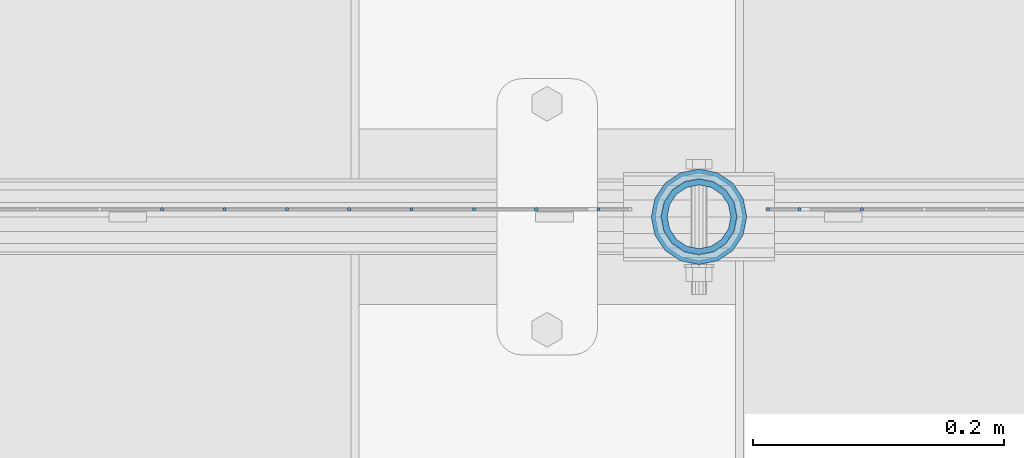
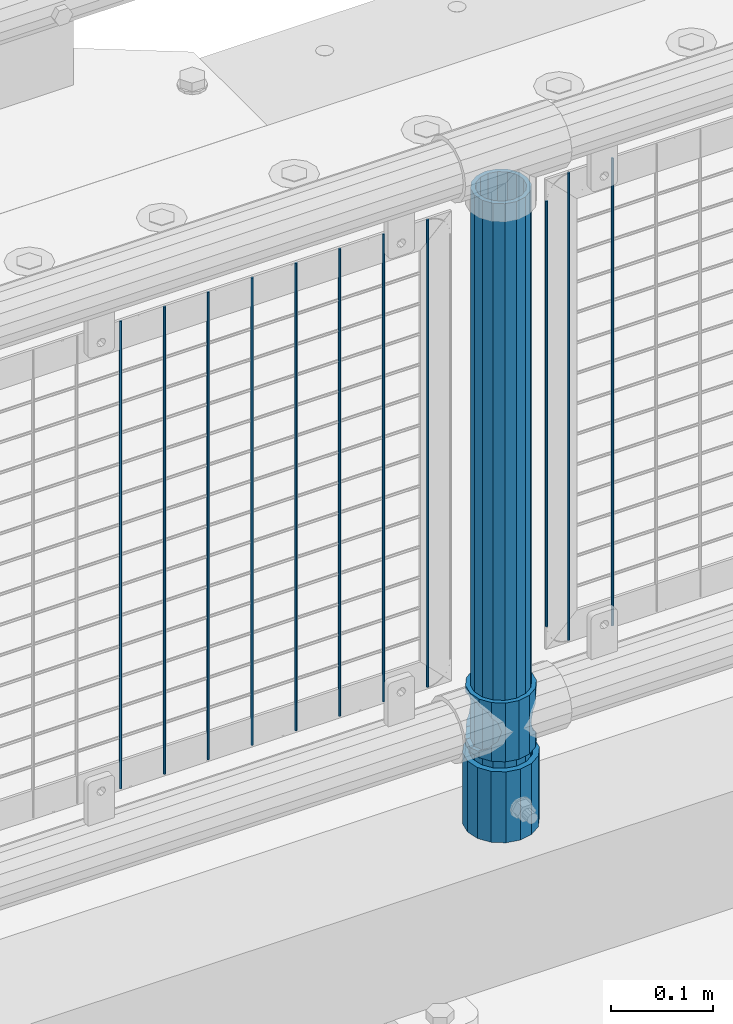
# One storey, part 70 of 257: 14 columns.
"""IFC2X3 building model written with IfcOpenShell, lengths in millimetres."""

import ifcopenshell
import ifcopenshell.guid

model = None  # the IFC model being written
_history = None  # IfcOwnerHistory: only IFC2X3 demands one
_inside = {}  # id of a spatial element -> (the spatial element, [elements in it])
_under = {}  # id of a project, library or spatial element -> (it, [spatial elements below it])
_declared = {}  # id of a project -> (the project, [libraries it declares])
_typed = {}  # id of a type object -> (the type object, [elements of that type])
_made_of = {}  # id of a material, layer set ... -> (it, [elements and type objects made of it])


def new_model(schema):
    """Start an empty IFC model of exactly this schema.

    Asked for "IFC4X3", IfcOpenShell would pick the latest addendum, in which some entities
    have other attributes; the version numbers below select the first issue.
    IFC2X3 requires an IfcOwnerHistory on every rooted entity: one is made here for all.
    """
    global model, _history
    if schema == "IFC4X3":
        model = ifcopenshell.file(schema_version=(4, 3, 0, 0))
    else:
        model = ifcopenshell.file(schema=schema)
    _inside.clear()
    _under.clear()
    _declared.clear()
    _typed.clear()
    _made_of.clear()
    _history = None
    if model.schema == "IFC2X3":
        org = make("IfcOrganization", Name="unknown")
        user = make(
            "IfcPersonAndOrganization",
            ThePerson=make("IfcPerson", FamilyName="unknown"),
            TheOrganization=org,
        )
        app = make(
            "IfcApplication",
            ApplicationDeveloper=org,
            Version="unknown",
            ApplicationFullName="unknown",
            ApplicationIdentifier="unknown",
        )
        _history = make(
            "IfcOwnerHistory",
            OwningUser=user,
            OwningApplication=app,
            ChangeAction="ADDED",
            CreationDate=0,
        )
    return model


def make(cls, **values):
    """One entity of the class cls with the attributes given. An attribute that is None is left unset."""
    return model.create_entity(
        cls, **{name: value for name, value in values.items() if value is not None}
    )


def rooted(cls, **values):
    """An entity with a GlobalId (a new one), such as an element, a storey or a relation."""
    return make(cls, GlobalId=ifcopenshell.guid.new(), OwnerHistory=_history, **values)


def si_unit(unit_type, name, prefix=None):
    """IfcSIUnit, for example si_unit("LENGTHUNIT", "METRE", prefix="MILLI")."""
    return make("IfcSIUnit", UnitType=unit_type, Prefix=prefix, Name=name)


def assignment(units):
    """IfcUnitAssignment: the units of a project."""
    return None if units is None else make("IfcUnitAssignment", Units=units)


def point(xyz):
    """IfcCartesianPoint."""
    return None if xyz is None else make("IfcCartesianPoint", Coordinates=xyz)


def direction(xyz):
    """IfcDirection."""
    return None if xyz is None else make("IfcDirection", DirectionRatios=xyz)


def frame(location, z_axis=None, x_axis=None):
    """IfcAxis2Placement3D, a coordinate frame: its origin and axes. An axis left out is left unset."""
    return make(
        "IfcAxis2Placement3D",
        Location=point(location),
        Axis=direction(z_axis),
        RefDirection=direction(x_axis),
    )


def origin_with_axes():
    """The frame at (0, 0, 0) with the z axis (0, 0, 1) and the x axis (1, 0, 0) written out."""
    return frame((0.0, 0.0, 0.0), z_axis=(0.0, 0.0, 1.0), x_axis=(1.0, 0.0, 0.0))


def place(relative_to, where):
    """IfcLocalPlacement: puts the frame where relative to a parent placement (None: the world)."""
    return make(
        "IfcLocalPlacement", PlacementRelTo=relative_to, RelativePlacement=where
    )


def context(
    kind, dimensions, precision=None, world=None, true_north=None, identifier=None
):
    """IfcGeometricRepresentationContext, for example the 3D "Model" context."""
    return make(
        "IfcGeometricRepresentationContext",
        ContextIdentifier=identifier,
        ContextType=kind,
        CoordinateSpaceDimension=dimensions,
        Precision=precision,
        WorldCoordinateSystem=world,
        TrueNorth=true_north,
    )


def subcontext(parent, identifier, kind, view, scale=None):
    """IfcGeometricRepresentationSubContext, for example "Body" below "Model"."""
    return make(
        "IfcGeometricRepresentationSubContext",
        ContextIdentifier=identifier,
        ContextType=kind,
        ParentContext=parent,
        TargetScale=scale,
        TargetView=view,
    )


def project(units=None, contexts=None):
    """IfcProject with its units and contexts."""
    return rooted(
        "IfcProject",
        Name="project",
        RepresentationContexts=contexts,
        UnitsInContext=assignment(units),
    )


def spatial(cls, under=None, at=None, **own):
    """A site, building, storey or space (cls), placed at a placement, below another one or the project."""
    s = rooted(cls, ObjectPlacement=at, **own)
    if under is not None:
        _under.setdefault(under.id(), (under, []))[1].append(s)
    return s


def faces_of(points, faces, orient=None, outer=None):
    """IfcFace entities. A face is a list of loops; a loop is a list of indices into points, from 0.

    orient and outer hold one flag for each loop. By default every Orientation is true, the
    first loop of a face is its IfcFaceOuterBound and the others are IfcFaceBound.
    """
    made = []
    for i, loops in enumerate(faces):
        bounds = []
        for j, loop in enumerate(loops):
            is_outer = j == 0 if outer is None else outer[i][j]
            bounds.append(
                make(
                    "IfcFaceOuterBound" if is_outer else "IfcFaceBound",
                    Bound=make("IfcPolyLoop", Polygon=[points[k] for k in loop]),
                    Orientation=True if orient is None else orient[i][j],
                )
            )
        made.append(make("IfcFace", Bounds=bounds))
    return made


def faceted_brep(points, faces, orient=None, outer=None, voids=None):
    """IfcFacetedBrep: a solid bounded by flat faces; with voids (closed shells), ...WithVoids."""
    shared = [point(p) for p in points]
    hull = make("IfcClosedShell", CfsFaces=faces_of(shared, faces, orient, outer))
    if voids is None:
        return make("IfcFacetedBrep", Outer=hull)
    return make(
        "IfcFacetedBrepWithVoids",
        Outer=hull,
        Voids=[
            make(cls, CfsFaces=faces_of(shared, fs, o, b)) for cls, fs, o, b in voids
        ],
    )


def shape(context_of_items, identifier, shape_type, items):
    """IfcShapeRepresentation: the items that make up one representation, for example the "Body"."""
    return make(
        "IfcShapeRepresentation",
        ContextOfItems=context_of_items,
        RepresentationIdentifier=identifier,
        RepresentationType=shape_type,
        Items=items,
    )


def material(Name=None, Category=None):
    """IfcMaterial."""
    return make("IfcMaterial", Name=Name, Category=Category)


def made_of(thing, what):
    """Note that an element or type object is made of a material, layer set ...; save() writes the relation."""
    if what is not None:
        _made_of.setdefault(what.id(), (what, []))[1].append(thing)
    return thing


def type_object(cls, material=None, **own):
    """A type object (cls), such as IfcWallType, which elements share."""
    return made_of(rooted(cls, **own), material)


def element(
    cls,
    number,
    at=None,
    inside=None,
    cuts=None,
    type_object=None,
    material=None,
    context=None,
    identifier="Body",
    shape_type=None,
    held_by="IfcProductDefinitionShape",
    body=None,
    shapes=None,
    **own,
):
    """One element of the class cls, such as IfcWall. Its Tag is "e" and its number.

    at: its placement. inside: the storey or other place that contains it. cuts: it is an
    opening in that element (IfcRelVoidsElement). A single representation is given by context,
    identifier, shape_type and body (its items); several are given by shapes. held_by: the class
    of the entity that holds the representations. save() writes the other relations.
    """
    e = rooted(cls, Tag="e%d" % number, ObjectPlacement=at, **own)
    if body is not None:
        shapes = [shape(context, identifier, shape_type, body)]
    if shapes is not None:
        e.Representation = make(held_by, Representations=shapes)
    if inside is not None:
        _inside.setdefault(inside.id(), (inside, []))[1].append(e)
    if cuts is not None:
        rooted(
            "IfcRelVoidsElement", RelatingBuildingElement=cuts, RelatedOpeningElement=e
        )
    if type_object is not None:
        _typed.setdefault(type_object.id(), (type_object, []))[1].append(e)
    return made_of(e, material)


def aggregate(whole, parts):
    """IfcRelAggregates: a whole, such as a stair, and the parts it consists of."""
    return rooted("IfcRelAggregates", RelatingObject=whole, RelatedObjects=parts)


def save(model, path):
    """Write the relations noted so far, then the file.

    IfcRelAggregates (storeys below a building ...), IfcRelContainedInSpatialStructure (elements
    in a storey), IfcRelDefinesByType, IfcRelAssociatesMaterial and IfcRelDeclares: one each for
    every whole, place, type object, material and project.
    """
    for whole, parts in _under.values():
        aggregate(whole, parts)
    for where, things in _inside.values():
        rooted(
            "IfcRelContainedInSpatialStructure",
            RelatedElements=things,
            RelatingStructure=where,
        )
    for kind, things in _typed.values():
        rooted("IfcRelDefinesByType", RelatedObjects=things, RelatingType=kind)
    for what, things in _made_of.values():
        rooted("IfcRelAssociatesMaterial", RelatedObjects=things, RelatingMaterial=what)
    for by, libraries in _declared.values():
        rooted("IfcRelDeclares", RelatingContext=by, RelatedDefinitions=libraries)
    model.write(path)


model = new_model("IFC2X3")

# Units and contexts
model_context = context("Model", 3, precision=1e-05, world=origin_with_axes())
body_context = subcontext(model_context, "Body", "Model", "MODEL_VIEW")
ifc_project = project(units=[si_unit("LENGTHUNIT", "METRE", prefix="MILLI"), si_unit("AREAUNIT", "SQUARE_METRE"), si_unit("VOLUMEUNIT", "CUBIC_METRE"), si_unit("MASSUNIT", "GRAM", prefix="KILO"), si_unit("TIMEUNIT", "SECOND"), si_unit("PLANEANGLEUNIT", "RADIAN"), si_unit("SOLIDANGLEUNIT", "STERADIAN"), si_unit("THERMODYNAMICTEMPERATUREUNIT", "DEGREE_CELSIUS"), si_unit("LUMINOUSINTENSITYUNIT", "LUMEN")], contexts=[model_context])

# Site, building, storey
site_placement = place(None, origin_with_axes())
site = spatial("IfcSite", under=ifc_project, at=site_placement, CompositionType="ELEMENT")
building_placement = place(site_placement, origin_with_axes())
building = spatial("IfcBuilding", under=site, at=building_placement, Name="Standard", CompositionType="ELEMENT")
storey_placement = place(building_placement, origin_with_axes())
storey = spatial("IfcBuildingStorey", under=building, at=storey_placement, Name="Undefined", CompositionType="ELEMENT", Elevation=0.0)

# Columns
ifc_material_1 = material()
column_type_1 = type_object("IfcColumnType", PredefinedType="NOTDEFINED")
column_1_placement = place(storey_placement, frame((46271.0, 10664.5, 168.02), z_axis=(0.0, 1.0, 0.0), x_axis=(0.0, 0.0, 1.0)))
element("IfcColumn", 1, at=column_1_placement, inside=storey, type_object=column_type_1, material=ifc_material_1, context=body_context, shape_type="Brep", body=[
    faceted_brep([(0.0, -31.75, 0.0), (0.0, -29.3331751572332, 12.1501989775916), (85.0, -29.3331751572332, 12.1501989775916), (85.0, -31.75, 0.0), (0.0, -22.4506403026753, 22.4506403026735), (85.0, -22.4506403026753, 22.4506403026735), (0.0, -12.1501989775934, 29.3331751572332), (85.0, -12.1501989775934, 29.3331751572332), (0.0, 0.0, 31.75), (85.0, 0.0, 31.75), (0.0, 12.1501989775934, 29.3331751572332), (85.0, 12.1501989775934, 29.3331751572332), (0.0, 22.4506403026753, 22.4506403026735), (85.0, 22.4506403026753, 22.4506403026735), (0.0, 29.3331751572332, 12.1501989775916), (85.0, 29.3331751572332, 12.1501989775916), (0.0, 31.75, 0.0), (85.0, 31.75, 0.0), (0.0, 29.3331751572332, -12.1501989775916), (85.0, 29.3331751572332, -12.1501989775916), (0.0, 22.4506403026753, -22.4506403026735), (85.0, 22.4506403026753, -22.4506403026735), (0.0, 12.1501989775934, -29.3331751572332), (85.0, 12.1501989775934, -29.3331751572332), (0.0, 0.0, -31.75), (85.0, 0.0, -31.75), (0.0, -12.1501989775934, -29.3331751572332), (85.0, -12.1501989775934, -29.3331751572332), (0.0, -22.4506403026753, -22.4506403026735), (85.0, -22.4506403026753, -22.4506403026735), (0.0, -29.3331751572332, -12.1501989775916), (85.0, -29.3331751572332, -12.1501989775916), (0.0, -38.0500000000029, 0.0), (0.0, -35.1536162120537, -14.561104601491), (85.0, -35.1536162120537, -14.561104601491), (85.0, -38.0500000000029, 0.0), (0.0, -26.9054130241493, -26.9054130241475), (85.0, -26.9054130241493, -26.9054130241475), (0.0, -14.5611046014892, -35.1536162120537), (85.0, -14.5611046014892, -35.1536162120537), (0.0, 0.0, -38.0499999999993), (85.0, 0.0, -38.0499999999993), (0.0, 14.5611046014892, -35.1536162120537), (85.0, 14.5611046014892, -35.1536162120537), (0.0, 26.9054130241493, -26.9054130241475), (85.0, 26.9054130241493, -26.9054130241475), (0.0, 35.1536162120537, -14.561104601491), (85.0, 35.1536162120537, -14.561104601491), (0.0, 38.0500000000029, 0.0), (85.0, 38.0500000000029, 0.0), (0.0, 35.1536162120537, 14.561104601491), (85.0, 35.1536162120537, 14.561104601491), (0.0, 26.9054130241493, 26.9054130241475), (85.0, 26.9054130241493, 26.9054130241475), (0.0, 14.5611046014892, 35.1536162120537), (85.0, 14.5611046014892, 35.1536162120537), (0.0, 0.0, 38.0499999999993), (85.0, 0.0, 38.0499999999993), (0.0, -14.5611046014892, 35.1536162120537), (85.0, -14.5611046014892, 35.1536162120537), (0.0, -26.9054130241493, 26.9054130241475), (85.0, -26.9054130241493, 26.9054130241475), (0.0, -35.1536162120537, 14.561104601491), (85.0, -35.1536162120537, 14.561104601491)], [[[0, 1, 2, 3]], [[1, 4, 5, 2]], [[4, 6, 7, 5]], [[6, 8, 9, 7]], [[8, 10, 11, 9]], [[10, 12, 13, 11]], [[12, 14, 15, 13]], [[14, 16, 17, 15]], [[16, 18, 19, 17]], [[18, 20, 21, 19]], [[20, 22, 23, 21]], [[22, 24, 25, 23]], [[24, 26, 27, 25]], [[26, 28, 29, 27]], [[28, 30, 31, 29]], [[30, 0, 3, 31]], [[32, 33, 34, 35]], [[33, 36, 37, 34]], [[36, 38, 39, 37]], [[38, 40, 41, 39]], [[40, 42, 43, 41]], [[42, 44, 45, 43]], [[44, 46, 47, 45]], [[46, 48, 49, 47]], [[48, 50, 51, 49]], [[50, 52, 53, 51]], [[52, 54, 55, 53]], [[54, 56, 57, 55]], [[56, 58, 59, 57]], [[58, 60, 61, 59]], [[60, 62, 63, 61]], [[62, 32, 35, 63]], [[37, 39, 41, 43, 45, 47, 49, 51, 53, 55, 57, 59, 61, 63, 35, 34], [5, 7, 9, 11, 13, 15, 17, 19, 21, 23, 25, 27, 29, 31, 3, 2]], [[62, 60, 58, 56, 54, 52, 50, 48, 46, 44, 42, 40, 38, 36, 33, 32], [30, 28, 26, 24, 22, 20, 18, 16, 14, 12, 10, 8, 6, 4, 1, 0]]]),
])
ifc_material_2 = material(Name="Misc_Undefined")
column_type_2 = type_object("IfcColumnType", PredefinedType="NOTDEFINED")
column_2_placement = place(storey_placement, frame((46271.0, 10664.5, 263.02), z_axis=(-1.0, 0.0, 0.0), x_axis=(0.0, 0.0, 1.0)))
element("IfcColumn", 2, at=column_2_placement, inside=storey, type_object=column_type_2, material=ifc_material_2, context=body_context, shape_type="Brep", body=[
    faceted_brep([(63.1897438117172, 11.6144421722802, -32.8397438117245), (63.1897438117172, 11.6144421722802, -28.0397438117143), (56.6106908090114, 21.4606908090118, -21.4606908090136), (56.6106908090114, 21.4606908090118, -27.1226768591077), (61.9623795176756, 13.4513226476338, -32.4743655677739), (46.7644421722801, 28.0397438117179, -11.6144421722784), (46.7644421722801, 28.0397438117179, -20.0882031229921), (51.5310424080039, 24.8548033587067, -24.8548033587067), (35.1500000000015, 30.35, 0.0), (35.1499999999996, 30.3500000000004, -16.6306603983758), (23.5355578277192, 28.0397438117179, -11.6144421722784), (23.5355578277192, 28.0397438117179, -20.0882031229921), (18.7689575919954, 24.8548033587067, -24.8548033587067), (13.6893091909879, 21.4606908090118, -21.4606908090136), (13.6893091909879, 21.4606908090118, -27.1226768591077), (8.3376204823237, 13.4513226476338, -32.4743655677739), (7.11025618828211, 11.6144421722802, -28.0397438117143), (7.11025618828211, 11.6144421722802, -32.8397438117245), (4.79999999999961, 0.0, -30.3499999999985), (4.79999999999961, 0.0, -35.1500000000015), (7.11025618828205, -11.6144421722802, -28.0397438117143), (7.11025618828205, -11.6144421722802, -32.8397438117245), (13.6893091909879, -21.4606908090118, -21.4606908090136), (13.6893091909879, -21.4606908090118, -27.1226768591077), (8.33762048232484, -13.4513226476338, -32.4743655677739), (23.5355578277191, -28.0397438117179, -11.6144421722784), (23.5355578277191, -28.0397438117179, -20.0882031229849), (18.7689575919987, -24.8548033587067, -24.8548033587067), (35.1500000000015, -30.35, 0.0), (35.1499999999996, -30.3500000000004, -16.6306603983685), (46.7644421722801, -28.0397438117179, -11.6144421722784), (46.7644421722801, -28.0397438117179, -20.0882031229849), (51.5310424080038, -24.8548033587067, -24.8548033587067), (56.6106908090114, -21.4606908090118, -21.4606908090136), (56.6106908090114, -21.4606908090118, -27.1226768591077), (61.9623795176756, -13.4513226476338, -32.4743655677739), (63.1897438117172, -11.6144421722802, -28.0397438117143), (63.1897438117172, -11.6144421722802, -32.8397438117245), (65.4999999999997, 0.0, -30.3499999999985), (65.4999999999997, 0.0, -35.1500000000015), (0.0, -28.0397438117179, -11.6144421722784), (0.0, -30.3500000000004, 0.0), (0.0, -21.4606908090118, -21.4606908090136), (0.0, -11.6144421722802, -28.0397438117143), (0.0, 0.0, -30.3499999999985), (0.0, 11.6144421722802, -28.0397438117143), (0.0, 21.4606908090118, -21.4606908090136), (0.0, 28.0397438117179, -11.6144421722784), (0.0, 30.3500000000004, 0.0), (0.0, 28.0397438117179, 11.6144421722784), (23.5355578277192, 28.0397438117179, 11.6144421722784), (0.0, 21.4606908090118, 21.4606908090136), (13.6893091909879, 21.4606908090118, 21.4606908090136), (0.0, 11.6144421722802, 28.0397438117143), (7.11025618828211, 11.6144421722802, 28.0397438117143), (0.0, 0.0, 30.3499999999985), (4.79999999999961, 0.0, 30.3499999999985), (0.0, -11.6144421722802, 28.0397438117143), (7.11025618828205, -11.6144421722802, 28.0397438117143), (0.0, -21.4606908090118, 21.4606908090136), (13.6893091909879, -21.4606908090118, 21.4606908090136), (0.0, -28.0397438117179, 11.6144421722784), (23.5355578277191, -28.0397438117179, 11.6144421722784), (0.0, -32.4743655677721, 13.4513226476338), (0.0, -35.1499999999996, 0.0), (70.2999999999993, -35.1499999999996, 0.0), (70.2999999999993, -32.4743655677721, 13.4513226476338), (0.0, 13.4513226476338, -32.4743655677739), (0.0, 24.8548033587067, -24.8548033587067), (0.0, 0.0, -35.1499999999996), (0.0, -13.4513226476338, -32.4743655677739), (0.0, -24.8548033587067, -24.8548033587067), (0.0, -24.8548033587067, 24.8548033587067), (0.0, -13.4513226476338, 32.4743655677739), (0.0, 0.0, 35.1499999999996), (0.0, 13.4513226476338, 32.4743655677739), (0.0, 24.8548033587067, 24.8548033587067), (0.0, 32.4743655677721, 13.4513226476338), (0.0, 35.1499999999996, 0.0), (0.0, 32.4743655677721, -13.4513226476338), (0.0, -32.4743655677721, -13.4513226476338), (70.2999999999993, 32.4743655677721, 13.4513226476338), (70.2999999999993, 35.1499999999996, 0.0), (70.2999999999993, 32.4743655677721, -13.4513226476338), (70.2999999999993, 24.8548033587067, -24.8548033587067), (70.2999999999993, 13.4513226476338, -32.4743655677739), (70.2999999999993, 0.0, -35.1500000000015), (70.2999999999993, -13.4513226476338, -32.4743655677739), (70.2999999999993, -24.8548033587067, -24.8548033587067), (70.2999999999993, -32.4743655677721, -13.4513226476338), (70.2999999999993, 28.0397438117179, 11.6144421722784), (70.2999999999993, 21.4606908090118, 21.4606908090136), (56.6106908090114, 21.4606908090118, 21.4606908090136), (46.7644421722801, 28.0397438117179, 11.6144421722784), (70.2999999999993, 11.6144421722802, 28.0397438117143), (63.1897438117172, 11.6144421722802, 28.0397438117143), (70.2999999999993, 0.0, 30.3499999999985), (65.4999999999997, 0.0, 30.3499999999985), (70.2999999999993, -11.6144421722802, 28.0397438117143), (63.1897438117172, -11.6144421722802, 28.0397438117143), (70.2999999999993, -21.4606908090118, 21.4606908090136), (56.6106908090114, -21.4606908090118, 21.4606908090136), (70.2999999999993, -28.0397438117179, 11.6144421722784), (46.7644421722801, -28.0397438117179, 11.6144421722784), (70.2999999999993, -11.6144421722802, -28.0397438117143), (70.2999999999993, 0.0, -30.3499999999985), (70.2999999999993, -21.4606908090118, -21.4606908090136), (70.2999999999993, -28.0397438117179, -11.6144421722784), (70.2999999999993, -30.3500000000004, 0.0), (70.2999999999993, 24.8548033587067, 24.8548033587067), (70.2999999999993, 13.4513226476338, 32.4743655677739), (70.2999999999993, 0.0, 35.1500000000015), (70.2999999999993, -13.4513226476338, 32.4743655677739), (70.2999999999993, -24.8548033587067, 24.8548033587067), (70.2999999999993, 30.3500000000004, 0.0), (70.2999999999993, 28.0397438117179, -11.6144421722784), (70.2999999999993, 21.4606908090118, -21.4606908090136), (70.2999999999993, 11.6144421722802, -28.0397438117143), (61.9623795176756, 13.4513226476338, 32.4743655677739), (51.5310424080039, 24.8548033587067, 24.8548033587067), (56.6106908090114, 21.4606908090118, 27.1226768591077), (65.4999999999997, 0.0, 35.1500000000015), (63.1897438117172, 11.6144421722802, 32.8397438117172), (63.1897438117172, -11.6144421722802, 32.8397438117172), (61.9623795176756, -13.4513226476338, 32.4743655677739), (56.6106908090114, -21.4606908090118, 27.1226768591077), (51.5310424080071, -24.8548033587067, 24.8548033587067), (18.7689575919987, -24.8548033587067, 24.8548033587067), (46.7644421722801, -28.0397438117179, 20.0882031229703), (35.1499999999996, -30.3500000000004, 16.6306603983539), (23.5355578277191, -28.0397438117179, 20.0882031229703), (8.3376204823237, -13.4513226476338, 32.4743655677739), (13.6893091909879, -21.4606908090118, 27.1226768591077), (4.79999999999961, 0.0, 35.1500000000015), (7.11025618828205, -11.6144421722802, 32.8397438117172), (7.11025618828211, 11.6144421722802, 32.8397438117172), (8.3376204823237, 13.4513226476338, 32.4743655677739), (13.6893091909879, 21.4606908090118, 27.1226768591077), (18.7689575919954, 24.8548033587067, 24.8548033587067), (23.5355578277192, 28.0397438117179, 20.0882031229849), (35.1499999999996, 30.3500000000004, 16.6306603983685), (46.7644421722801, 28.0397438117179, 20.0882031229849)], [[[0, 1, 2, 3, 4]], [[3, 2, 5, 6, 7]], [[6, 5, 8, 9]], [[9, 8, 10, 11]], [[12, 11, 10, 13, 14]], [[15, 14, 13, 16, 17]], [[17, 16, 18, 19]], [[19, 18, 20, 21]], [[21, 20, 22, 23, 24]], [[23, 22, 25, 26, 27]], [[26, 25, 28, 29]], [[29, 28, 30, 31]], [[32, 31, 30, 33, 34]], [[35, 34, 33, 36, 37]], [[37, 36, 38, 39]], [[39, 38, 1, 0]], [[40, 41, 28, 25]], [[42, 40, 25, 22]], [[43, 42, 22, 20]], [[44, 43, 20, 18]], [[45, 44, 18, 16]], [[46, 45, 16, 13]], [[47, 46, 13, 10]], [[48, 47, 10, 8]], [[49, 48, 8, 50]], [[51, 49, 50, 52]], [[53, 51, 52, 54]], [[55, 53, 54, 56]], [[57, 55, 56, 58]], [[59, 57, 58, 60]], [[61, 59, 60, 62]], [[41, 61, 62, 28]], [[63, 64, 65, 66]], [[67, 68, 12, 14, 15]], [[69, 67, 15, 17, 19]], [[24, 70, 69, 19, 21]], [[27, 71, 70, 24, 23]], [[63, 72, 73, 74, 75, 76, 77, 78, 79, 68, 67, 69, 70, 71, 80, 64], [40, 42, 43, 44, 45, 46, 47, 48, 49, 51, 53, 55, 57, 59, 61, 41]], [[78, 77, 81, 82]], [[79, 78, 82, 83]], [[9, 11, 12, 68, 79, 83, 84, 7, 6]], [[7, 84, 85, 4, 3]], [[4, 85, 86, 39, 0]], [[87, 88, 32, 34, 35]], [[86, 87, 35, 37, 39]], [[88, 89, 80, 71, 27, 26, 29, 31, 32]], [[64, 80, 89, 65]], [[90, 91, 92, 93]], [[91, 94, 95, 92]], [[94, 96, 97, 95]], [[96, 98, 99, 97]], [[98, 100, 101, 99]], [[100, 102, 103, 101]], [[104, 105, 38, 36]], [[106, 104, 36, 33]], [[107, 106, 33, 30]], [[108, 107, 30, 28]], [[102, 108, 28, 103]], [[88, 87, 86, 85, 84, 83, 82, 81, 109, 110, 111, 112, 113, 66, 65, 89], [100, 98, 96, 94, 91, 90, 114, 115, 116, 117, 105, 104, 106, 107, 108, 102]], [[118, 110, 109, 119, 120]], [[121, 111, 110, 118, 122]], [[112, 111, 121, 123, 124]], [[113, 112, 124, 125, 126]], [[127, 72, 63, 66, 113, 126, 128, 129, 130]], [[131, 73, 72, 127, 132]], [[133, 74, 73, 131, 134]], [[75, 74, 133, 135, 136]], [[76, 75, 136, 137, 138]], [[119, 109, 81, 77, 76, 138, 139, 140, 141]], [[92, 120, 119, 141, 93]], [[95, 122, 118, 120, 92]], [[97, 121, 122, 95]], [[99, 123, 121, 97]], [[101, 125, 124, 123, 99]], [[103, 128, 126, 125, 101]], [[28, 129, 128, 103]], [[62, 130, 129, 28]], [[60, 132, 127, 130, 62]], [[58, 134, 131, 132, 60]], [[56, 133, 134, 58]], [[54, 135, 133, 56]], [[52, 137, 136, 135, 54]], [[50, 139, 138, 137, 52]], [[8, 140, 139, 50]], [[93, 141, 140, 8]], [[114, 90, 93, 8]], [[115, 114, 8, 5]], [[116, 115, 5, 2]], [[117, 116, 2, 1]], [[105, 117, 1, 38]]]),
])
column_type_3 = type_object("IfcColumnType", PredefinedType="NOTDEFINED")
column_3_placement = place(storey_placement, frame((46271.0, 10664.5, 168.02), z_axis=(-1.0, 0.0, 0.0), x_axis=(0.0, 0.0, 1.0)))
element("IfcColumn", 3, at=column_3_placement, inside=storey, type_object=column_type_3, material=ifc_material_1, context=body_context, shape_type="Brep", body=[
    faceted_brep([(0.0, -25.3500000000004, 0.0), (0.0, -23.4203461491616, 9.70102501045767), (760.0, -23.4203461491616, 9.70102501045767), (760.0, -25.3500000000004, 0.0), (0.0, -17.9251569030785, 17.9251569030821), (760.0, -17.9251569030785, 17.9251569030821), (0.0, -9.70102501045585, 23.4203461491634), (760.0, -9.70102501045585, 23.4203461491634), (0.0, 0.0, 25.3499999999985), (760.0, 0.0, 25.3499999999985), (0.0, 9.70102501045585, 23.4203461491634), (760.0, 9.70102501045585, 23.4203461491634), (0.0, 17.9251569030785, 17.9251569030821), (760.0, 17.9251569030785, 17.9251569030821), (0.0, 23.4203461491616, 9.70102501045767), (760.0, 23.4203461491616, 9.70102501045767), (0.0, 25.3500000000004, 0.0), (760.0, 25.3500000000004, 0.0), (0.0, 23.4203461491616, -9.70102501045767), (760.0, 23.4203461491616, -9.70102501045767), (0.0, 17.9251569030785, -17.9251569030821), (760.0, 17.9251569030785, -17.9251569030821), (0.0, 9.70102501045585, -23.4203461491634), (760.0, 9.70102501045585, -23.4203461491634), (0.0, 0.0, -25.3499999999985), (760.0, 0.0, -25.3499999999985), (0.0, -9.70102501045585, -23.4203461491634), (760.0, -9.70102501045585, -23.4203461491634), (0.0, -17.9251569030785, -17.9251569030821), (760.0, -17.9251569030785, -17.9251569030821), (0.0, -23.4203461491616, -9.70102501045767), (760.0, -23.4203461491616, -9.70102501045767), (0.0, -30.1499999999996, 0.0), (0.0, -27.8549679052157, -11.5379054858058), (760.0, -27.8549679052157, -11.5379054858058), (760.0, -30.1499999999996, 0.0), (0.0, -21.3192694527752, -21.3192694527752), (760.0, -21.3192694527752, -21.3192694527752), (0.0, -11.5379054858076, -27.8549679052157), (760.0, -11.5379054858076, -27.8549679052157), (0.0, 0.0, -30.1500000000015), (760.0, 0.0, -30.1500000000015), (0.0, 11.5379054858076, -27.8549679052157), (760.0, 11.5379054858076, -27.8549679052157), (0.0, 21.3192694527752, -21.3192694527752), (760.0, 21.3192694527752, -21.3192694527752), (0.0, 27.8549679052157, -11.5379054858058), (760.0, 27.8549679052157, -11.5379054858058), (0.0, 30.1499999999996, 0.0), (760.0, 30.1499999999996, 0.0), (0.0, 27.8549679052157, 11.5379054858058), (760.0, 27.8549679052157, 11.5379054858058), (0.0, 21.3192694527752, 21.3192694527752), (760.0, 21.3192694527752, 21.3192694527752), (0.0, 11.5379054858076, 27.8549679052157), (760.0, 11.5379054858076, 27.8549679052157), (0.0, 0.0, 30.1500000000015), (760.0, 0.0, 30.1500000000015), (0.0, -11.5379054858076, 27.8549679052157), (760.0, -11.5379054858076, 27.8549679052157), (0.0, -21.3192694527752, 21.3192694527752), (760.0, -21.3192694527752, 21.3192694527752), (0.0, -27.8549679052157, 11.5379054858058), (760.0, -27.8549679052157, 11.5379054858058)], [[[0, 1, 2, 3]], [[1, 4, 5, 2]], [[4, 6, 7, 5]], [[6, 8, 9, 7]], [[8, 10, 11, 9]], [[10, 12, 13, 11]], [[12, 14, 15, 13]], [[14, 16, 17, 15]], [[16, 18, 19, 17]], [[18, 20, 21, 19]], [[20, 22, 23, 21]], [[22, 24, 25, 23]], [[24, 26, 27, 25]], [[26, 28, 29, 27]], [[28, 30, 31, 29]], [[30, 0, 3, 31]], [[32, 33, 34, 35]], [[33, 36, 37, 34]], [[36, 38, 39, 37]], [[38, 40, 41, 39]], [[40, 42, 43, 41]], [[42, 44, 45, 43]], [[44, 46, 47, 45]], [[46, 48, 49, 47]], [[48, 50, 51, 49]], [[50, 52, 53, 51]], [[52, 54, 55, 53]], [[54, 56, 57, 55]], [[56, 58, 59, 57]], [[58, 60, 61, 59]], [[60, 62, 63, 61]], [[62, 32, 35, 63]], [[37, 39, 41, 43, 45, 47, 49, 51, 53, 55, 57, 59, 61, 63, 35, 34], [5, 7, 9, 11, 13, 15, 17, 19, 21, 23, 25, 27, 29, 31, 3, 2]], [[62, 60, 58, 56, 54, 52, 50, 48, 46, 44, 42, 40, 38, 36, 33, 32], [30, 28, 26, 24, 22, 20, 18, 16, 14, 12, 10, 8, 6, 4, 1, 0]]]),
])
column_type_4 = type_object("IfcColumnType", Name="D3", PredefinedType="NOTDEFINED")
column_4_placement = place(storey_placement, frame((46400.6551724138, 10670.5, 353.02), z_axis=(-0.999999999962839, 0.0, 8.62099999968473e-06), x_axis=(8.62099999949798e-06, 0.0, 0.999999999962839)))
element("IfcColumn", 4, at=column_4_placement, inside=storey, type_object=column_type_4, material=ifc_material_2, ObjectType="D3", context=body_context, shape_type="Brep", body=[
    faceted_brep([(0.0, -1.5, -5.6843418860808e-14), (0.0, -0.750000000001819, -1.29903810567669), (560.0, -0.75, -1.29903810567339), (560.0, -1.5, 0.0), (7.27595761418343e-12, 0.749999999998181, -1.29903810567669), (560.0, 0.75, -1.29903810567339), (0.0, 1.5, -5.6843418860808e-14), (560.0, 1.5, 0.0), (7.27595761418343e-12, 0.749999999998181, 1.29903810567669), (560.0, 0.75, 1.29903810567339), (0.0, -0.750000000001819, 1.29903810567669), (560.0, -0.75, 1.29903810567339)], [[[0, 1, 2, 3]], [[1, 4, 5, 2]], [[4, 6, 7, 5]], [[6, 8, 9, 7]], [[8, 10, 11, 9]], [[10, 0, 3, 11]], [[5, 7, 9, 11, 3, 2]], [[10, 8, 6, 4, 1, 0]]]),
])
column_5_placement = place(storey_placement, frame((46326.0, 10670.5, 378.02), z_axis=(-1.0, 0.0, 0.0), x_axis=(0.0, 0.0, 1.0)))
element("IfcColumn", 5, at=column_5_placement, inside=storey, type_object=column_type_4, material=ifc_material_2, ObjectType="D3", context=body_context, shape_type="Brep", body=[
    faceted_brep([(0.0, -1.5, -5.6843418860808e-14), (0.0, -0.750000000001819, -1.29903810567669), (510.0, -0.75, -1.29903810567339), (510.0, -1.5, 0.0), (7.27595761418343e-12, 0.749999999998181, -1.29903810567669), (510.0, 0.75, -1.29903810567339), (0.0, 1.5, -5.6843418860808e-14), (510.0, 1.5, 0.0), (7.27595761418343e-12, 0.749999999998181, 1.29903810567669), (510.0, 0.75, 1.29903810567339), (0.0, -0.750000000001819, 1.29903810567669), (510.0, -0.75, 1.29903810567339)], [[[0, 1, 2, 3]], [[1, 4, 5, 2]], [[4, 6, 7, 5]], [[6, 8, 9, 7]], [[8, 10, 11, 9]], [[10, 0, 3, 11]], [[5, 7, 9, 11, 3, 2]], [[10, 8, 6, 4, 1, 0]]]),
])
for number, where, z_axis, x_axis in (
    (6, (46351.0, 10670.5, 353.02), (-1.0, 0.0, 0.0), (0.0, 0.0, 1.0)),
    (7, (46190.995, 10670.5, 353.02), (-1.0, 0.0, 0.0), (0.0, 0.0, 1.0)),
    (8, (46141.34, 10670.5, 353.02), (-1.0, 0.0, 0.0), (0.0, 0.0, 1.0)),
    (9, (46091.685, 10670.5, 353.02), (-1.0, 0.0, 0.0), (0.0, 0.0, 1.0)),
    (10, (46042.03, 10670.5, 353.02), (-1.0, 0.0, 0.0), (0.0, 0.0, 1.0)),
    (11, (45992.375, 10670.5, 353.02), (-1.0, 0.0, 0.0), (0.0, 0.0, 1.0)),
    (12, (45942.72, 10670.5, 353.02), (-1.0, 0.0, 0.0), (0.0, 0.0, 1.0)),
    (13, (45893.065, 10670.5, 353.02), (-1.0, 0.0, 0.0), (0.0, 0.0, 1.0)),
    (14, (45843.41, 10670.5, 353.02), (-1.0, 0.0, 0.0), (0.0, 0.0, 1.0)),
):
    element("IfcColumn", number, at=place(storey_placement, frame(where, z_axis=z_axis, x_axis=x_axis)), inside=storey, type_object=column_type_4, material=ifc_material_2, ObjectType="D3", context=body_context, shape_type="Brep", body=[
        faceted_brep([(0.0, -1.5, -5.6843418860808e-14), (0.0, -0.750000000001819, -1.29903810567669), (560.0, -0.75, -1.29903810567339), (560.0, -1.5, 0.0), (7.27595761418343e-12, 0.749999999998181, -1.29903810567669), (560.0, 0.75, -1.29903810567339), (0.0, 1.5, -5.6843418860808e-14), (560.0, 1.5, 0.0), (7.27595761418343e-12, 0.749999999998181, 1.29903810567669), (560.0, 0.75, 1.29903810567339), (0.0, -0.750000000001819, 1.29903810567669), (560.0, -0.75, 1.29903810567339)], [[[0, 1, 2, 3]], [[1, 4, 5, 2]], [[4, 6, 7, 5]], [[6, 8, 9, 7]], [[8, 10, 11, 9]], [[10, 0, 3, 11]], [[5, 7, 9, 11, 3, 2]], [[10, 8, 6, 4, 1, 0]]]),
    ])

save(model, "model.ifc")
